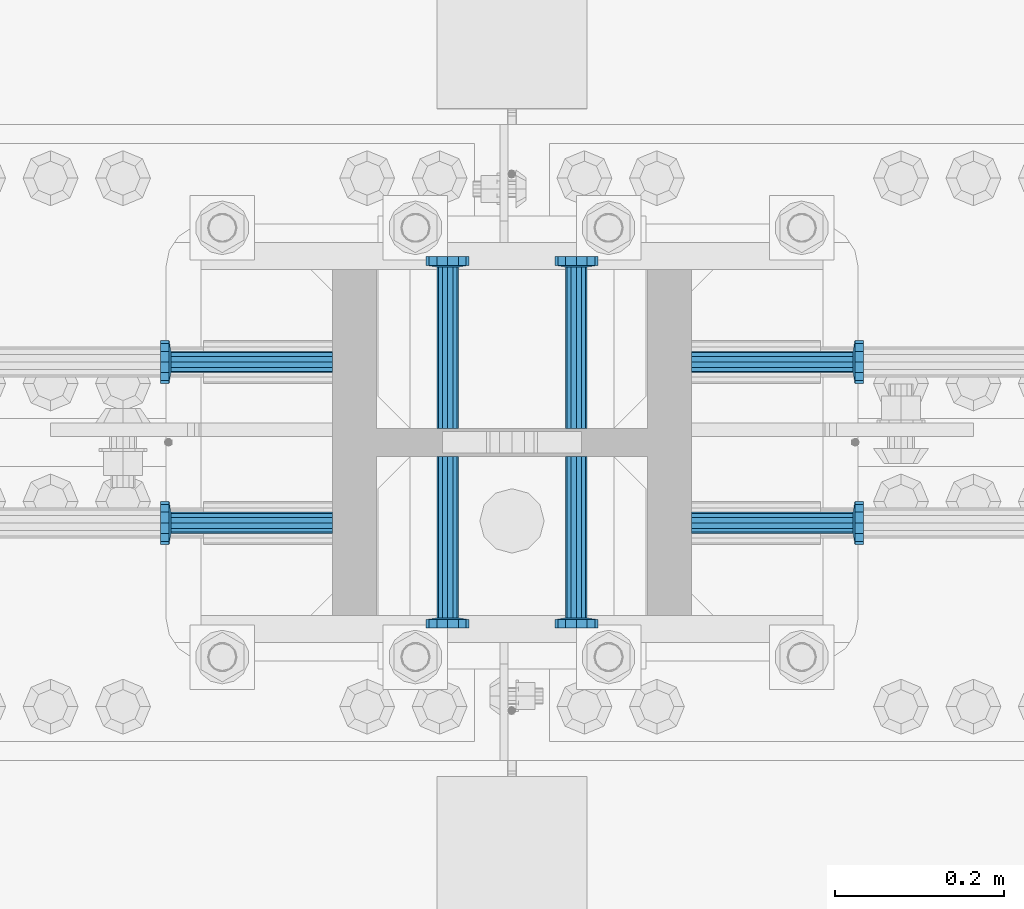
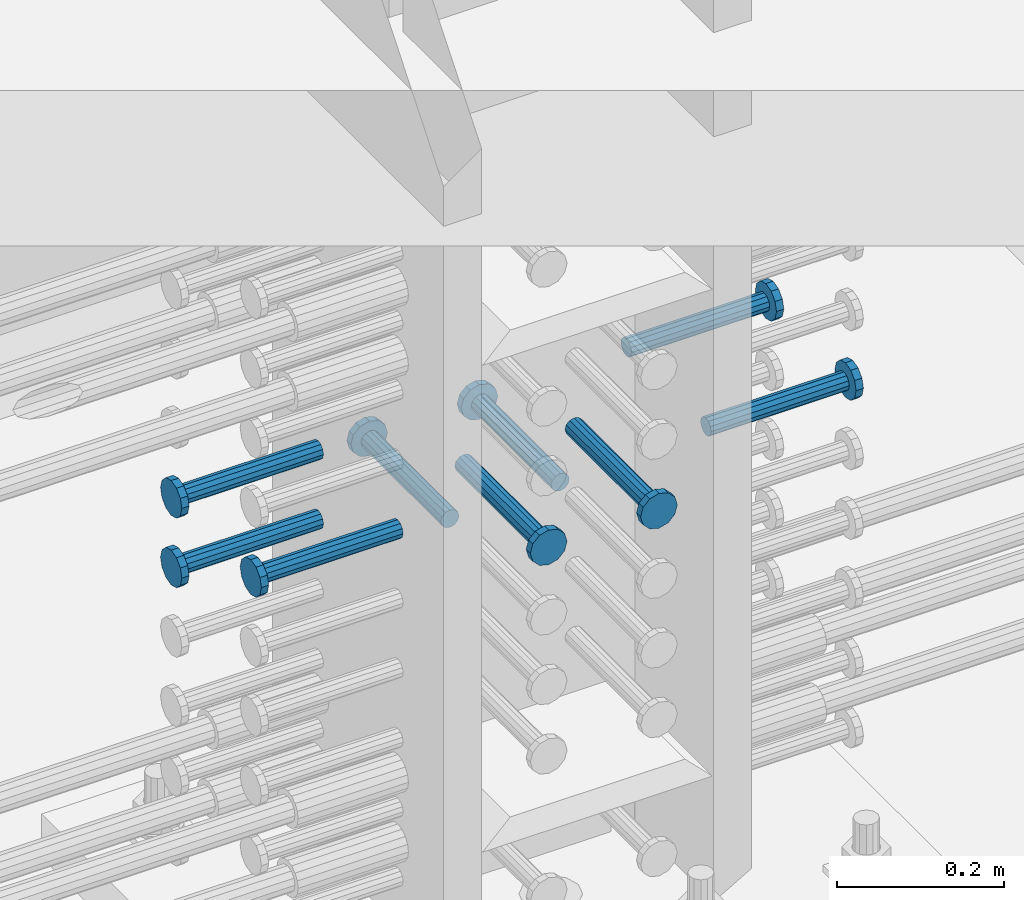
# One storey, part 1219 of 1763: 9 beams, 1 element without a shape of its own.
"""IFC2X3 building model written with IfcOpenShell, lengths in millimetres."""

from ifc_helpers import new_model, si_unit, frame, origin_with_axes, place, context, subcontext, project, spatial, faceted_brep, material, type_object, element, aggregate, save


model = new_model("IFC2X3")

# Units and contexts
model_context = context("Model", 3, precision=1e-05, world=origin_with_axes())
body_context = subcontext(model_context, "Body", "Model", "MODEL_VIEW")
ifc_project = project(units=[si_unit("LENGTHUNIT", "METRE", prefix="MILLI"), si_unit("AREAUNIT", "SQUARE_METRE"), si_unit("VOLUMEUNIT", "CUBIC_METRE"), si_unit("MASSUNIT", "GRAM", prefix="KILO"), si_unit("TIMEUNIT", "SECOND"), si_unit("PLANEANGLEUNIT", "RADIAN"), si_unit("SOLIDANGLEUNIT", "STERADIAN"), si_unit("THERMODYNAMICTEMPERATUREUNIT", "DEGREE_CELSIUS"), si_unit("LUMINOUSINTENSITYUNIT", "LUMEN")], contexts=[model_context])

# Site, building, storey
site_placement = place(None, origin_with_axes())
site = spatial("IfcSite", under=ifc_project, at=site_placement, CompositionType="ELEMENT")
building_placement = place(site_placement, origin_with_axes())
building = spatial("IfcBuilding", under=site, at=building_placement, Name="Undefined", CompositionType="ELEMENT")
storey_placement = place(building_placement, origin_with_axes())
storey = spatial("IfcBuildingStorey", under=building, at=storey_placement, Name="Undefined", CompositionType="ELEMENT", Elevation=0.0)

# Assembly, beams
assembly_placement = place(storey_placement, origin_with_axes())
assembly = element("IfcElementAssembly", 1, at=assembly_placement, inside=storey, Name="COLUMN", AssemblyPlace="NOTDEFINED", PredefinedType="RIGID_FRAME")
ifc_material = material(Name="STEEL/A108")
beam_type = type_object("IfcBeamType", PredefinedType="NOTDEFINED")
beam_1_placement = place(assembly_placement, frame((-61807.1622049631, 552.449999999823, 4521.20000000005), z_axis=(0.0, 1.0, 0.0), x_axis=(-1.0, 0.0, 0.0)))
beam_1 = element("IfcBeam", 2, at=beam_1_placement, type_object=beam_type, material=ifc_material, Name="HEADED STUD ANCHOR", context=body_context, shape_type="Brep", body=[
    faceted_brep([(0.0, -12.6999999999971, -1.81898940354586e-12), (3.63797880709171e-12, -11.0, -6.34999990463257), (191.00799999576, -11.0, -6.34999990454889), (191.007999995752, -12.6999998092651, 8.36735125631094e-11), (7.27595761418343e-12, -6.34999990463257, -11.0), (191.00799999576, -6.34999990463257, -10.9999999999163), (3.63797880709171e-12, 0.0, -12.6999998092651), (191.00799999576, 0.0, -12.6999998091815), (7.27595761418343e-12, 6.34999990463257, -11.0), (191.00799999576, 6.34999990463257, -10.9999999999163), (3.63797880709171e-12, 11.0, -6.34999990463257), (191.00799999576, 11.0, -6.34999990454889), (0.0, 12.6999999999971, -1.81898940354586e-12), (191.007999995752, 12.6999998092651, 8.36735125631094e-11), (0.0, 11.0, 6.34999990463257), (191.007999995752, 11.0, 6.34999990471624), (-3.63797880709171e-12, 6.34999990463257, 11.0), (191.007999995749, 6.34999990463257, 11.0000000000837), (-3.63797880709171e-12, 0.0, 12.6999998092651), (191.007999995749, 0.0, 12.6999998093488), (-3.63797880709171e-12, -6.34999990463257, 11.0), (191.007999995749, -6.34999990463257, 11.0000000000837), (0.0, -11.0, 6.34999990463257), (191.007999995752, -11.0, 6.34999990471624), (193.039999995715, -22.0, -12.6999998091796), (193.039999995708, -25.3999996185303, 8.54925019666553e-11), (193.039999995719, -12.6999998092651, -21.9999999999145), (193.039999995719, 0.0, -25.3999996184448), (193.039999995719, 12.6999998092651, -21.9999999999145), (193.039999995715, 22.0, -12.6999998091796), (193.039999995708, 25.3999996185303, 8.54925019666553e-11), (193.039999995704, 22.0, 12.6999998093506), (193.039999995701, 12.6999998092651, 22.0000000000855), (193.039999995697, 0.0, 25.3999996186158), (193.039999995701, -12.6999998092651, 22.0000000000855), (193.039999995704, -22.0, 12.6999998093506), (203.199999995486, -22.0, -12.6999998091742), (203.199999995482, -25.3999996185303, 9.09494701772928e-11), (203.199999995493, -12.6999998092651, -21.9999999999091), (203.199999995493, 0.0, -25.3999996184393), (203.199999995493, 12.6999998092651, -21.9999999999091), (203.199999995486, 22.0, -12.6999998091742), (203.199999995482, 25.3999996185303, 9.09494701772928e-11), (203.199999995479, 22.0, 12.6999998093561), (203.199999995475, 12.6999998092651, 22.0000000000909), (203.199999995471, 0.0, 25.3999996186212), (203.199999995475, -12.6999998092651, 22.0000000000909), (203.199999995479, -22.0, 12.6999998093561)], [[[0, 1, 2, 3]], [[1, 4, 5, 2]], [[4, 6, 7, 5]], [[6, 8, 9, 7]], [[8, 10, 11, 9]], [[10, 12, 13, 11]], [[12, 14, 15, 13]], [[14, 16, 17, 15]], [[16, 18, 19, 17]], [[18, 20, 21, 19]], [[20, 22, 23, 21]], [[22, 0, 3, 23]], [[22, 20, 18, 16, 14, 12, 10, 8, 6, 4, 1, 0]], [[3, 2, 24, 25]], [[2, 5, 26, 24]], [[5, 7, 27, 26]], [[7, 9, 28, 27]], [[9, 11, 29, 28]], [[11, 13, 30, 29]], [[13, 15, 31, 30]], [[15, 17, 32, 31]], [[17, 19, 33, 32]], [[19, 21, 34, 33]], [[21, 23, 35, 34]], [[23, 3, 25, 35]], [[25, 24, 36, 37]], [[24, 26, 38, 36]], [[26, 27, 39, 38]], [[27, 28, 40, 39]], [[28, 29, 41, 40]], [[29, 30, 42, 41]], [[30, 31, 43, 42]], [[31, 32, 44, 43]], [[32, 33, 45, 44]], [[33, 34, 46, 45]], [[34, 35, 47, 46]], [[35, 25, 37, 47]], [[38, 39, 40, 41, 42, 43, 44, 45, 46, 47, 37, 36]]]),
])
beam_2_placement = place(assembly_placement, frame((-61807.1622736986, 361.949999999998, 4521.20000000005), z_axis=(0.0, 1.0, 0.0), x_axis=(-1.0, 0.0, 0.0)))
beam_2 = element("IfcBeam", 3, at=beam_2_placement, type_object=beam_type, material=ifc_material, Name="HEADED STUD ANCHOR", context=body_context, shape_type="Brep", body=[
    faceted_brep([(0.0, -12.6999999999971, -1.81898940354586e-12), (3.63797880709171e-12, -11.0, -6.34999990463257), (191.00799999576, -11.0, -6.34999990454889), (191.007999995752, -12.6999998092651, 8.36735125631094e-11), (7.27595761418343e-12, -6.34999990463257, -11.0), (191.00799999576, -6.34999990463257, -10.9999999999163), (3.63797880709171e-12, 0.0, -12.6999998092651), (191.00799999576, 0.0, -12.6999998091815), (7.27595761418343e-12, 6.34999990463257, -11.0), (191.00799999576, 6.34999990463257, -10.9999999999163), (3.63797880709171e-12, 11.0, -6.34999990463257), (191.00799999576, 11.0, -6.34999990454889), (0.0, 12.6999999999971, -1.81898940354586e-12), (191.007999995752, 12.6999998092651, 8.36735125631094e-11), (0.0, 11.0, 6.34999990463257), (191.007999995752, 11.0, 6.34999990471624), (-3.63797880709171e-12, 6.34999990463257, 11.0), (191.007999995749, 6.34999990463257, 11.0000000000837), (-3.63797880709171e-12, 0.0, 12.6999998092651), (191.007999995749, 0.0, 12.6999998093488), (-3.63797880709171e-12, -6.34999990463257, 11.0), (191.007999995749, -6.34999990463257, 11.0000000000837), (0.0, -11.0, 6.34999990463257), (191.007999995752, -11.0, 6.34999990471624), (193.039999995715, -22.0, -12.6999998091796), (193.039999995708, -25.3999996185303, 8.54925019666553e-11), (193.039999995719, -12.6999998092651, -21.9999999999145), (193.039999995719, 0.0, -25.3999996184448), (193.039999995719, 12.6999998092651, -21.9999999999145), (193.039999995715, 22.0, -12.6999998091796), (193.039999995708, 25.3999996185303, 8.54925019666553e-11), (193.039999995704, 22.0, 12.6999998093506), (193.039999995701, 12.6999998092651, 22.0000000000855), (193.039999995697, 0.0, 25.3999996186158), (193.039999995701, -12.6999998092651, 22.0000000000855), (193.039999995704, -22.0, 12.6999998093506), (203.199999995486, -22.0, -12.6999998091742), (203.199999995482, -25.3999996185303, 9.09494701772928e-11), (203.199999995493, -12.6999998092651, -21.9999999999091), (203.199999995493, 0.0, -25.3999996184393), (203.199999995493, 12.6999998092651, -21.9999999999091), (203.199999995486, 22.0, -12.6999998091742), (203.199999995482, 25.3999996185303, 9.09494701772928e-11), (203.199999995479, 22.0, 12.6999998093561), (203.199999995475, 12.6999998092651, 22.0000000000909), (203.199999995471, 0.0, 25.3999996186212), (203.199999995475, -12.6999998092651, 22.0000000000909), (203.199999995479, -22.0, 12.6999998093561)], [[[0, 1, 2, 3]], [[1, 4, 5, 2]], [[4, 6, 7, 5]], [[6, 8, 9, 7]], [[8, 10, 11, 9]], [[10, 12, 13, 11]], [[12, 14, 15, 13]], [[14, 16, 17, 15]], [[16, 18, 19, 17]], [[18, 20, 21, 19]], [[20, 22, 23, 21]], [[22, 0, 3, 23]], [[22, 20, 18, 16, 14, 12, 10, 8, 6, 4, 1, 0]], [[3, 2, 24, 25]], [[2, 5, 26, 24]], [[5, 7, 27, 26]], [[7, 9, 28, 27]], [[9, 11, 29, 28]], [[11, 13, 30, 29]], [[13, 15, 31, 30]], [[15, 17, 32, 31]], [[17, 19, 33, 32]], [[19, 21, 34, 33]], [[21, 23, 35, 34]], [[23, 3, 25, 35]], [[25, 24, 36, 37]], [[24, 26, 38, 36]], [[26, 27, 39, 38]], [[27, 28, 40, 39]], [[28, 29, 41, 40]], [[29, 30, 42, 41]], [[30, 31, 43, 42]], [[31, 32, 44, 43]], [[32, 33, 45, 44]], [[33, 34, 46, 45]], [[34, 35, 47, 46]], [[35, 25, 37, 47]], [[38, 39, 40, 41, 42, 43, 44, 45, 46, 47, 37, 36]]]),
])
beam_3_placement = place(assembly_placement, frame((-61670.6373420916, 440.53099988573, 4521.20000000005), z_axis=(1.0, 0.0, 0.0), x_axis=(0.0, -1.0, 0.0)))
beam_3 = element("IfcBeam", 4, at=beam_3_placement, type_object=beam_type, material=ifc_material, Name="HEADED STUD ANCHOR", context=body_context, shape_type="Brep", body=[
    faceted_brep([(0.0, -12.6999999999971, -1.81898940354586e-12), (3.63797880709171e-12, -11.0, -6.34999990463257), (191.00799999576, -11.0, -6.34999990454889), (191.007999995752, -12.6999998092651, 8.36735125631094e-11), (7.27595761418343e-12, -6.34999990463257, -11.0), (191.00799999576, -6.34999990463257, -10.9999999999163), (3.63797880709171e-12, 0.0, -12.6999998092651), (191.00799999576, 0.0, -12.6999998091815), (7.27595761418343e-12, 6.34999990463257, -11.0), (191.00799999576, 6.34999990463257, -10.9999999999163), (3.63797880709171e-12, 11.0, -6.34999990463257), (191.00799999576, 11.0, -6.34999990454889), (0.0, 12.6999999999971, -1.81898940354586e-12), (191.007999995752, 12.6999998092651, 8.36735125631094e-11), (0.0, 11.0, 6.34999990463257), (191.007999995752, 11.0, 6.34999990471624), (-3.63797880709171e-12, 6.34999990463257, 11.0), (191.007999995749, 6.34999990463257, 11.0000000000837), (-3.63797880709171e-12, 0.0, 12.6999998092651), (191.007999995749, 0.0, 12.6999998093488), (-3.63797880709171e-12, -6.34999990463257, 11.0), (191.007999995749, -6.34999990463257, 11.0000000000837), (0.0, -11.0, 6.34999990463257), (191.007999995752, -11.0, 6.34999990471624), (193.039999995715, -22.0, -12.6999998091796), (193.039999995708, -25.3999996185303, 8.54925019666553e-11), (193.039999995719, -12.6999998092651, -21.9999999999145), (193.039999995719, 0.0, -25.3999996184448), (193.039999995719, 12.6999998092651, -21.9999999999145), (193.039999995715, 22.0, -12.6999998091796), (193.039999995708, 25.3999996185303, 8.54925019666553e-11), (193.039999995704, 22.0, 12.6999998093506), (193.039999995701, 12.6999998092651, 22.0000000000855), (193.039999995697, 0.0, 25.3999996186158), (193.039999995701, -12.6999998092651, 22.0000000000855), (193.039999995704, -22.0, 12.6999998093506), (203.199999995486, -22.0, -12.6999998091742), (203.199999995482, -25.3999996185303, 9.09494701772928e-11), (203.199999995493, -12.6999998092651, -21.9999999999091), (203.199999995493, 0.0, -25.3999996184393), (203.199999995493, 12.6999998092651, -21.9999999999091), (203.199999995486, 22.0, -12.6999998091742), (203.199999995482, 25.3999996185303, 9.09494701772928e-11), (203.199999995479, 22.0, 12.6999998093561), (203.199999995475, 12.6999998092651, 22.0000000000909), (203.199999995471, 0.0, 25.3999996186212), (203.199999995475, -12.6999998092651, 22.0000000000909), (203.199999995479, -22.0, 12.6999998093561)], [[[0, 1, 2, 3]], [[1, 4, 5, 2]], [[4, 6, 7, 5]], [[6, 8, 9, 7]], [[8, 10, 11, 9]], [[10, 12, 13, 11]], [[12, 14, 15, 13]], [[14, 16, 17, 15]], [[16, 18, 19, 17]], [[18, 20, 21, 19]], [[20, 22, 23, 21]], [[22, 0, 3, 23]], [[22, 20, 18, 16, 14, 12, 10, 8, 6, 4, 1, 0]], [[3, 2, 24, 25]], [[2, 5, 26, 24]], [[5, 7, 27, 26]], [[7, 9, 28, 27]], [[9, 11, 29, 28]], [[11, 13, 30, 29]], [[13, 15, 31, 30]], [[15, 17, 32, 31]], [[17, 19, 33, 32]], [[19, 21, 34, 33]], [[21, 23, 35, 34]], [[23, 3, 25, 35]], [[25, 24, 36, 37]], [[24, 26, 38, 36]], [[26, 27, 39, 38]], [[27, 28, 40, 39]], [[28, 29, 41, 40]], [[29, 30, 42, 41]], [[30, 31, 43, 42]], [[31, 32, 44, 43]], [[32, 33, 45, 44]], [[33, 34, 46, 45]], [[34, 35, 47, 46]], [[35, 25, 37, 47]], [[38, 39, 40, 41, 42, 43, 44, 45, 46, 47, 37, 36]]]),
])
beam_4_placement = place(assembly_placement, frame((-61518.2373420926, 440.531000000006, 4521.20000000005), z_axis=(1.0, 0.0, 0.0), x_axis=(0.0, -1.0, 0.0)))
beam_4 = element("IfcBeam", 5, at=beam_4_placement, type_object=beam_type, material=ifc_material, Name="HEADED STUD ANCHOR", context=body_context, shape_type="Brep", body=[
    faceted_brep([(0.0, -12.6999999999971, -1.81898940354586e-12), (3.63797880709171e-12, -11.0, -6.34999990463257), (191.00799999576, -11.0, -6.34999990454889), (191.007999995752, -12.6999998092651, 8.36735125631094e-11), (7.27595761418343e-12, -6.34999990463257, -11.0), (191.00799999576, -6.34999990463257, -10.9999999999163), (3.63797880709171e-12, 0.0, -12.6999998092651), (191.00799999576, 0.0, -12.6999998091815), (7.27595761418343e-12, 6.34999990463257, -11.0), (191.00799999576, 6.34999990463257, -10.9999999999163), (3.63797880709171e-12, 11.0, -6.34999990463257), (191.00799999576, 11.0, -6.34999990454889), (0.0, 12.6999999999971, -1.81898940354586e-12), (191.007999995752, 12.6999998092651, 8.36735125631094e-11), (0.0, 11.0, 6.34999990463257), (191.007999995752, 11.0, 6.34999990471624), (-3.63797880709171e-12, 6.34999990463257, 11.0), (191.007999995749, 6.34999990463257, 11.0000000000837), (-3.63797880709171e-12, 0.0, 12.6999998092651), (191.007999995749, 0.0, 12.6999998093488), (-3.63797880709171e-12, -6.34999990463257, 11.0), (191.007999995749, -6.34999990463257, 11.0000000000837), (0.0, -11.0, 6.34999990463257), (191.007999995752, -11.0, 6.34999990471624), (193.039999995715, -22.0, -12.6999998091796), (193.039999995708, -25.3999996185303, 8.54925019666553e-11), (193.039999995719, -12.6999998092651, -21.9999999999145), (193.039999995719, 0.0, -25.3999996184448), (193.039999995719, 12.6999998092651, -21.9999999999145), (193.039999995715, 22.0, -12.6999998091796), (193.039999995708, 25.3999996185303, 8.54925019666553e-11), (193.039999995704, 22.0, 12.6999998093506), (193.039999995701, 12.6999998092651, 22.0000000000855), (193.039999995697, 0.0, 25.3999996186158), (193.039999995701, -12.6999998092651, 22.0000000000855), (193.039999995704, -22.0, 12.6999998093506), (203.199999995486, -22.0, -12.6999998091742), (203.199999995482, -25.3999996185303, 9.09494701772928e-11), (203.199999995493, -12.6999998092651, -21.9999999999091), (203.199999995493, 0.0, -25.3999996184393), (203.199999995493, 12.6999998092651, -21.9999999999091), (203.199999995486, 22.0, -12.6999998091742), (203.199999995482, 25.3999996185303, 9.09494701772928e-11), (203.199999995479, 22.0, 12.6999998093561), (203.199999995475, 12.6999998092651, 22.0000000000909), (203.199999995471, 0.0, 25.3999996186212), (203.199999995475, -12.6999998092651, 22.0000000000909), (203.199999995479, -22.0, 12.6999998093561)], [[[0, 1, 2, 3]], [[1, 4, 5, 2]], [[4, 6, 7, 5]], [[6, 8, 9, 7]], [[8, 10, 11, 9]], [[10, 12, 13, 11]], [[12, 14, 15, 13]], [[14, 16, 17, 15]], [[16, 18, 19, 17]], [[18, 20, 21, 19]], [[20, 22, 23, 21]], [[22, 0, 3, 23]], [[22, 20, 18, 16, 14, 12, 10, 8, 6, 4, 1, 0]], [[3, 2, 24, 25]], [[2, 5, 26, 24]], [[5, 7, 27, 26]], [[7, 9, 28, 27]], [[9, 11, 29, 28]], [[11, 13, 30, 29]], [[13, 15, 31, 30]], [[15, 17, 32, 31]], [[17, 19, 33, 32]], [[19, 21, 34, 33]], [[21, 23, 35, 34]], [[23, 3, 25, 35]], [[25, 24, 36, 37]], [[24, 26, 38, 36]], [[26, 27, 39, 38]], [[27, 28, 40, 39]], [[28, 29, 41, 40]], [[29, 30, 42, 41]], [[30, 31, 43, 42]], [[31, 32, 44, 43]], [[32, 33, 45, 44]], [[33, 34, 46, 45]], [[34, 35, 47, 46]], [[35, 25, 37, 47]], [[38, 39, 40, 41, 42, 43, 44, 45, 46, 47, 37, 36]]]),
])
beam_5_placement = place(assembly_placement, frame((-61381.7123210203, 361.950000000609, 4521.20000000005), z_axis=(0.0, 1.0, 0.0), x_axis=(1.0, 0.0, 0.0)))
beam_5 = element("IfcBeam", 6, at=beam_5_placement, type_object=beam_type, material=ifc_material, Name="HEADED STUD ANCHOR", context=body_context, shape_type="Brep", body=[
    faceted_brep([(0.0, -12.6999999999971, -1.81898940354586e-12), (3.63797880709171e-12, -11.0, -6.34999990463257), (191.00799999576, -11.0, -6.34999990454889), (191.007999995752, -12.6999998092651, 8.36735125631094e-11), (7.27595761418343e-12, -6.34999990463257, -11.0), (191.00799999576, -6.34999990463257, -10.9999999999163), (3.63797880709171e-12, 0.0, -12.6999998092651), (191.00799999576, 0.0, -12.6999998091815), (7.27595761418343e-12, 6.34999990463257, -11.0), (191.00799999576, 6.34999990463257, -10.9999999999163), (3.63797880709171e-12, 11.0, -6.34999990463257), (191.00799999576, 11.0, -6.34999990454889), (0.0, 12.6999999999971, -1.81898940354586e-12), (191.007999995752, 12.6999998092651, 8.36735125631094e-11), (0.0, 11.0, 6.34999990463257), (191.007999995752, 11.0, 6.34999990471624), (-3.63797880709171e-12, 6.34999990463257, 11.0), (191.007999995749, 6.34999990463257, 11.0000000000837), (-3.63797880709171e-12, 0.0, 12.6999998092651), (191.007999995749, 0.0, 12.6999998093488), (-3.63797880709171e-12, -6.34999990463257, 11.0), (191.007999995749, -6.34999990463257, 11.0000000000837), (0.0, -11.0, 6.34999990463257), (191.007999995752, -11.0, 6.34999990471624), (193.039999995715, -22.0, -12.6999998091796), (193.039999995708, -25.3999996185303, 8.54925019666553e-11), (193.039999995719, -12.6999998092651, -21.9999999999145), (193.039999995719, 0.0, -25.3999996184448), (193.039999995719, 12.6999998092651, -21.9999999999145), (193.039999995715, 22.0, -12.6999998091796), (193.039999995708, 25.3999996185303, 8.54925019666553e-11), (193.039999995704, 22.0, 12.6999998093506), (193.039999995701, 12.6999998092651, 22.0000000000855), (193.039999995697, 0.0, 25.3999996186158), (193.039999995701, -12.6999998092651, 22.0000000000855), (193.039999995704, -22.0, 12.6999998093506), (203.199999995486, -22.0, -12.6999998091742), (203.199999995482, -25.3999996185303, 9.09494701772928e-11), (203.199999995493, -12.6999998092651, -21.9999999999091), (203.199999995493, 0.0, -25.3999996184393), (203.199999995493, 12.6999998092651, -21.9999999999091), (203.199999995486, 22.0, -12.6999998091742), (203.199999995482, 25.3999996185303, 9.09494701772928e-11), (203.199999995479, 22.0, 12.6999998093561), (203.199999995475, 12.6999998092651, 22.0000000000909), (203.199999995471, 0.0, 25.3999996186212), (203.199999995475, -12.6999998092651, 22.0000000000909), (203.199999995479, -22.0, 12.6999998093561)], [[[0, 1, 2, 3]], [[1, 4, 5, 2]], [[4, 6, 7, 5]], [[6, 8, 9, 7]], [[8, 10, 11, 9]], [[10, 12, 13, 11]], [[12, 14, 15, 13]], [[14, 16, 17, 15]], [[16, 18, 19, 17]], [[18, 20, 21, 19]], [[20, 22, 23, 21]], [[22, 0, 3, 23]], [[22, 20, 18, 16, 14, 12, 10, 8, 6, 4, 1, 0]], [[3, 2, 24, 25]], [[2, 5, 26, 24]], [[5, 7, 27, 26]], [[7, 9, 28, 27]], [[9, 11, 29, 28]], [[11, 13, 30, 29]], [[13, 15, 31, 30]], [[15, 17, 32, 31]], [[17, 19, 33, 32]], [[19, 21, 34, 33]], [[21, 23, 35, 34]], [[23, 3, 25, 35]], [[25, 24, 36, 37]], [[24, 26, 38, 36]], [[26, 27, 39, 38]], [[27, 28, 40, 39]], [[28, 29, 41, 40]], [[29, 30, 42, 41]], [[30, 31, 43, 42]], [[31, 32, 44, 43]], [[32, 33, 45, 44]], [[33, 34, 46, 45]], [[34, 35, 47, 46]], [[35, 25, 37, 47]], [[38, 39, 40, 41, 42, 43, 44, 45, 46, 47, 37, 36]]]),
])
beam_6_placement = place(assembly_placement, frame((-61381.7122523598, 552.449999999998, 4521.20000000005), z_axis=(0.0, 1.0, 0.0), x_axis=(1.0, 0.0, 0.0)))
beam_6 = element("IfcBeam", 7, at=beam_6_placement, type_object=beam_type, material=ifc_material, Name="HEADED STUD ANCHOR", context=body_context, shape_type="Brep", body=[
    faceted_brep([(0.0, -12.6999999999971, -1.81898940354586e-12), (3.63797880709171e-12, -11.0, -6.34999990463257), (191.00799999576, -11.0, -6.34999990454889), (191.007999995752, -12.6999998092651, 8.36735125631094e-11), (7.27595761418343e-12, -6.34999990463257, -11.0), (191.00799999576, -6.34999990463257, -10.9999999999163), (3.63797880709171e-12, 0.0, -12.6999998092651), (191.00799999576, 0.0, -12.6999998091815), (7.27595761418343e-12, 6.34999990463257, -11.0), (191.00799999576, 6.34999990463257, -10.9999999999163), (3.63797880709171e-12, 11.0, -6.34999990463257), (191.00799999576, 11.0, -6.34999990454889), (0.0, 12.6999999999971, -1.81898940354586e-12), (191.007999995752, 12.6999998092651, 8.36735125631094e-11), (0.0, 11.0, 6.34999990463257), (191.007999995752, 11.0, 6.34999990471624), (-3.63797880709171e-12, 6.34999990463257, 11.0), (191.007999995749, 6.34999990463257, 11.0000000000837), (-3.63797880709171e-12, 0.0, 12.6999998092651), (191.007999995749, 0.0, 12.6999998093488), (-3.63797880709171e-12, -6.34999990463257, 11.0), (191.007999995749, -6.34999990463257, 11.0000000000837), (0.0, -11.0, 6.34999990463257), (191.007999995752, -11.0, 6.34999990471624), (193.039999995715, -22.0, -12.6999998091796), (193.039999995708, -25.3999996185303, 8.54925019666553e-11), (193.039999995719, -12.6999998092651, -21.9999999999145), (193.039999995719, 0.0, -25.3999996184448), (193.039999995719, 12.6999998092651, -21.9999999999145), (193.039999995715, 22.0, -12.6999998091796), (193.039999995708, 25.3999996185303, 8.54925019666553e-11), (193.039999995704, 22.0, 12.6999998093506), (193.039999995701, 12.6999998092651, 22.0000000000855), (193.039999995697, 0.0, 25.3999996186158), (193.039999995701, -12.6999998092651, 22.0000000000855), (193.039999995704, -22.0, 12.6999998093506), (203.199999995486, -22.0, -12.6999998091742), (203.199999995482, -25.3999996185303, 9.09494701772928e-11), (203.199999995493, -12.6999998092651, -21.9999999999091), (203.199999995493, 0.0, -25.3999996184393), (203.199999995493, 12.6999998092651, -21.9999999999091), (203.199999995486, 22.0, -12.6999998091742), (203.199999995482, 25.3999996185303, 9.09494701772928e-11), (203.199999995479, 22.0, 12.6999998093561), (203.199999995475, 12.6999998092651, 22.0000000000909), (203.199999995471, 0.0, 25.3999996186212), (203.199999995475, -12.6999998092651, 22.0000000000909), (203.199999995479, -22.0, 12.6999998093561)], [[[0, 1, 2, 3]], [[1, 4, 5, 2]], [[4, 6, 7, 5]], [[6, 8, 9, 7]], [[8, 10, 11, 9]], [[10, 12, 13, 11]], [[12, 14, 15, 13]], [[14, 16, 17, 15]], [[16, 18, 19, 17]], [[18, 20, 21, 19]], [[20, 22, 23, 21]], [[22, 0, 3, 23]], [[22, 20, 18, 16, 14, 12, 10, 8, 6, 4, 1, 0]], [[3, 2, 24, 25]], [[2, 5, 26, 24]], [[5, 7, 27, 26]], [[7, 9, 28, 27]], [[9, 11, 29, 28]], [[11, 13, 30, 29]], [[13, 15, 31, 30]], [[15, 17, 32, 31]], [[17, 19, 33, 32]], [[19, 21, 34, 33]], [[21, 23, 35, 34]], [[23, 3, 25, 35]], [[25, 24, 36, 37]], [[24, 26, 38, 36]], [[26, 27, 39, 38]], [[27, 28, 40, 39]], [[28, 29, 41, 40]], [[29, 30, 42, 41]], [[30, 31, 43, 42]], [[31, 32, 44, 43]], [[32, 33, 45, 44]], [[33, 34, 46, 45]], [[34, 35, 47, 46]], [[35, 25, 37, 47]], [[38, 39, 40, 41, 42, 43, 44, 45, 46, 47, 37, 36]]]),
])
beam_7_placement = place(assembly_placement, frame((-61518.2373431004, 473.869000000006, 4419.60000000004), z_axis=(1.0, 0.0, 0.0), x_axis=(0.0, 1.0, 0.0)))
beam_7 = element("IfcBeam", 8, at=beam_7_placement, type_object=beam_type, material=ifc_material, Name="HEADED STUD ANCHOR", context=body_context, shape_type="Brep", body=[
    faceted_brep([(0.0, -12.6999999999971, -1.81898940354586e-12), (3.63797880709171e-12, -11.0, -6.34999990463257), (191.00799999576, -11.0, -6.34999990454889), (191.007999995752, -12.6999998092651, 8.36735125631094e-11), (7.27595761418343e-12, -6.34999990463257, -11.0), (191.00799999576, -6.34999990463257, -10.9999999999163), (3.63797880709171e-12, 0.0, -12.6999998092651), (191.00799999576, 0.0, -12.6999998091815), (7.27595761418343e-12, 6.34999990463257, -11.0), (191.00799999576, 6.34999990463257, -10.9999999999163), (3.63797880709171e-12, 11.0, -6.34999990463257), (191.00799999576, 11.0, -6.34999990454889), (0.0, 12.6999999999971, -1.81898940354586e-12), (191.007999995752, 12.6999998092651, 8.36735125631094e-11), (0.0, 11.0, 6.34999990463257), (191.007999995752, 11.0, 6.34999990471624), (-3.63797880709171e-12, 6.34999990463257, 11.0), (191.007999995749, 6.34999990463257, 11.0000000000837), (-3.63797880709171e-12, 0.0, 12.6999998092651), (191.007999995749, 0.0, 12.6999998093488), (-3.63797880709171e-12, -6.34999990463257, 11.0), (191.007999995749, -6.34999990463257, 11.0000000000837), (0.0, -11.0, 6.34999990463257), (191.007999995752, -11.0, 6.34999990471624), (193.039999995715, -22.0, -12.6999998091796), (193.039999995708, -25.3999996185303, 8.54925019666553e-11), (193.039999995719, -12.6999998092651, -21.9999999999145), (193.039999995719, 0.0, -25.3999996184448), (193.039999995719, 12.6999998092651, -21.9999999999145), (193.039999995715, 22.0, -12.6999998091796), (193.039999995708, 25.3999996185303, 8.54925019666553e-11), (193.039999995704, 22.0, 12.6999998093506), (193.039999995701, 12.6999998092651, 22.0000000000855), (193.039999995697, 0.0, 25.3999996186158), (193.039999995701, -12.6999998092651, 22.0000000000855), (193.039999995704, -22.0, 12.6999998093506), (203.199999995486, -22.0, -12.6999998091742), (203.199999995482, -25.3999996185303, 9.09494701772928e-11), (203.199999995493, -12.6999998092651, -21.9999999999091), (203.199999995493, 0.0, -25.3999996184393), (203.199999995493, 12.6999998092651, -21.9999999999091), (203.199999995486, 22.0, -12.6999998091742), (203.199999995482, 25.3999996185303, 9.09494701772928e-11), (203.199999995479, 22.0, 12.6999998093561), (203.199999995475, 12.6999998092651, 22.0000000000909), (203.199999995471, 0.0, 25.3999996186212), (203.199999995475, -12.6999998092651, 22.0000000000909), (203.199999995479, -22.0, 12.6999998093561)], [[[0, 1, 2, 3]], [[1, 4, 5, 2]], [[4, 6, 7, 5]], [[6, 8, 9, 7]], [[8, 10, 11, 9]], [[10, 12, 13, 11]], [[12, 14, 15, 13]], [[14, 16, 17, 15]], [[16, 18, 19, 17]], [[18, 20, 21, 19]], [[20, 22, 23, 21]], [[22, 0, 3, 23]], [[22, 20, 18, 16, 14, 12, 10, 8, 6, 4, 1, 0]], [[3, 2, 24, 25]], [[2, 5, 26, 24]], [[5, 7, 27, 26]], [[7, 9, 28, 27]], [[9, 11, 29, 28]], [[11, 13, 30, 29]], [[13, 15, 31, 30]], [[15, 17, 32, 31]], [[17, 19, 33, 32]], [[19, 21, 34, 33]], [[21, 23, 35, 34]], [[23, 3, 25, 35]], [[25, 24, 36, 37]], [[24, 26, 38, 36]], [[26, 27, 39, 38]], [[27, 28, 40, 39]], [[28, 29, 41, 40]], [[29, 30, 42, 41]], [[30, 31, 43, 42]], [[31, 32, 44, 43]], [[32, 33, 45, 44]], [[33, 34, 46, 45]], [[34, 35, 47, 46]], [[35, 25, 37, 47]], [[38, 39, 40, 41, 42, 43, 44, 45, 46, 47, 37, 36]]]),
])
beam_8_placement = place(assembly_placement, frame((-61670.6373431002, 473.868999002865, 4419.60000000004), z_axis=(1.0, 0.0, 0.0), x_axis=(0.0, 1.0, 0.0)))
beam_8 = element("IfcBeam", 9, at=beam_8_placement, type_object=beam_type, material=ifc_material, Name="HEADED STUD ANCHOR", context=body_context, shape_type="Brep", body=[
    faceted_brep([(0.0, -12.6999999999971, -1.81898940354586e-12), (3.63797880709171e-12, -11.0, -6.34999990463257), (191.00799999576, -11.0, -6.34999990454889), (191.007999995752, -12.6999998092651, 8.36735125631094e-11), (7.27595761418343e-12, -6.34999990463257, -11.0), (191.00799999576, -6.34999990463257, -10.9999999999163), (3.63797880709171e-12, 0.0, -12.6999998092651), (191.00799999576, 0.0, -12.6999998091815), (7.27595761418343e-12, 6.34999990463257, -11.0), (191.00799999576, 6.34999990463257, -10.9999999999163), (3.63797880709171e-12, 11.0, -6.34999990463257), (191.00799999576, 11.0, -6.34999990454889), (0.0, 12.6999999999971, -1.81898940354586e-12), (191.007999995752, 12.6999998092651, 8.36735125631094e-11), (0.0, 11.0, 6.34999990463257), (191.007999995752, 11.0, 6.34999990471624), (-3.63797880709171e-12, 6.34999990463257, 11.0), (191.007999995749, 6.34999990463257, 11.0000000000837), (-3.63797880709171e-12, 0.0, 12.6999998092651), (191.007999995749, 0.0, 12.6999998093488), (-3.63797880709171e-12, -6.34999990463257, 11.0), (191.007999995749, -6.34999990463257, 11.0000000000837), (0.0, -11.0, 6.34999990463257), (191.007999995752, -11.0, 6.34999990471624), (193.039999995715, -22.0, -12.6999998091796), (193.039999995708, -25.3999996185303, 8.54925019666553e-11), (193.039999995719, -12.6999998092651, -21.9999999999145), (193.039999995719, 0.0, -25.3999996184448), (193.039999995719, 12.6999998092651, -21.9999999999145), (193.039999995715, 22.0, -12.6999998091796), (193.039999995708, 25.3999996185303, 8.54925019666553e-11), (193.039999995704, 22.0, 12.6999998093506), (193.039999995701, 12.6999998092651, 22.0000000000855), (193.039999995697, 0.0, 25.3999996186158), (193.039999995701, -12.6999998092651, 22.0000000000855), (193.039999995704, -22.0, 12.6999998093506), (203.199999995486, -22.0, -12.6999998091742), (203.199999995482, -25.3999996185303, 9.09494701772928e-11), (203.199999995493, -12.6999998092651, -21.9999999999091), (203.199999995493, 0.0, -25.3999996184393), (203.199999995493, 12.6999998092651, -21.9999999999091), (203.199999995486, 22.0, -12.6999998091742), (203.199999995482, 25.3999996185303, 9.09494701772928e-11), (203.199999995479, 22.0, 12.6999998093561), (203.199999995475, 12.6999998092651, 22.0000000000909), (203.199999995471, 0.0, 25.3999996186212), (203.199999995475, -12.6999998092651, 22.0000000000909), (203.199999995479, -22.0, 12.6999998093561)], [[[0, 1, 2, 3]], [[1, 4, 5, 2]], [[4, 6, 7, 5]], [[6, 8, 9, 7]], [[8, 10, 11, 9]], [[10, 12, 13, 11]], [[12, 14, 15, 13]], [[14, 16, 17, 15]], [[16, 18, 19, 17]], [[18, 20, 21, 19]], [[20, 22, 23, 21]], [[22, 0, 3, 23]], [[22, 20, 18, 16, 14, 12, 10, 8, 6, 4, 1, 0]], [[3, 2, 24, 25]], [[2, 5, 26, 24]], [[5, 7, 27, 26]], [[7, 9, 28, 27]], [[9, 11, 29, 28]], [[11, 13, 30, 29]], [[13, 15, 31, 30]], [[15, 17, 32, 31]], [[17, 19, 33, 32]], [[19, 21, 34, 33]], [[21, 23, 35, 34]], [[23, 3, 25, 35]], [[25, 24, 36, 37]], [[24, 26, 38, 36]], [[26, 27, 39, 38]], [[27, 28, 40, 39]], [[28, 29, 41, 40]], [[29, 30, 42, 41]], [[30, 31, 43, 42]], [[31, 32, 44, 43]], [[32, 33, 45, 44]], [[33, 34, 46, 45]], [[34, 35, 47, 46]], [[35, 25, 37, 47]], [[38, 39, 40, 41, 42, 43, 44, 45, 46, 47, 37, 36]]]),
])
beam_9_placement = place(assembly_placement, frame((-61807.1622049631, 552.449999999823, 4419.60000000004), z_axis=(0.0, 1.0, 0.0), x_axis=(-1.0, 0.0, 0.0)))
beam_9 = element("IfcBeam", 10, at=beam_9_placement, type_object=beam_type, material=ifc_material, Name="HEADED STUD ANCHOR", context=body_context, shape_type="Brep", body=[
    faceted_brep([(0.0, -12.6999999999971, -1.81898940354586e-12), (3.63797880709171e-12, -11.0, -6.34999990463257), (191.00799999576, -11.0, -6.34999990454889), (191.007999995752, -12.6999998092651, 8.36735125631094e-11), (7.27595761418343e-12, -6.34999990463257, -11.0), (191.00799999576, -6.34999990463257, -10.9999999999163), (3.63797880709171e-12, 0.0, -12.6999998092651), (191.00799999576, 0.0, -12.6999998091815), (7.27595761418343e-12, 6.34999990463257, -11.0), (191.00799999576, 6.34999990463257, -10.9999999999163), (3.63797880709171e-12, 11.0, -6.34999990463257), (191.00799999576, 11.0, -6.34999990454889), (0.0, 12.6999999999971, -1.81898940354586e-12), (191.007999995752, 12.6999998092651, 8.36735125631094e-11), (0.0, 11.0, 6.34999990463257), (191.007999995752, 11.0, 6.34999990471624), (-3.63797880709171e-12, 6.34999990463257, 11.0), (191.007999995749, 6.34999990463257, 11.0000000000837), (-3.63797880709171e-12, 0.0, 12.6999998092651), (191.007999995749, 0.0, 12.6999998093488), (-3.63797880709171e-12, -6.34999990463257, 11.0), (191.007999995749, -6.34999990463257, 11.0000000000837), (0.0, -11.0, 6.34999990463257), (191.007999995752, -11.0, 6.34999990471624), (193.039999995715, -22.0, -12.6999998091796), (193.039999995708, -25.3999996185303, 8.54925019666553e-11), (193.039999995719, -12.6999998092651, -21.9999999999145), (193.039999995719, 0.0, -25.3999996184448), (193.039999995719, 12.6999998092651, -21.9999999999145), (193.039999995715, 22.0, -12.6999998091796), (193.039999995708, 25.3999996185303, 8.54925019666553e-11), (193.039999995704, 22.0, 12.6999998093506), (193.039999995701, 12.6999998092651, 22.0000000000855), (193.039999995697, 0.0, 25.3999996186158), (193.039999995701, -12.6999998092651, 22.0000000000855), (193.039999995704, -22.0, 12.6999998093506), (203.199999995486, -22.0, -12.6999998091742), (203.199999995482, -25.3999996185303, 9.09494701772928e-11), (203.199999995493, -12.6999998092651, -21.9999999999091), (203.199999995493, 0.0, -25.3999996184393), (203.199999995493, 12.6999998092651, -21.9999999999091), (203.199999995486, 22.0, -12.6999998091742), (203.199999995482, 25.3999996185303, 9.09494701772928e-11), (203.199999995479, 22.0, 12.6999998093561), (203.199999995475, 12.6999998092651, 22.0000000000909), (203.199999995471, 0.0, 25.3999996186212), (203.199999995475, -12.6999998092651, 22.0000000000909), (203.199999995479, -22.0, 12.6999998093561)], [[[0, 1, 2, 3]], [[1, 4, 5, 2]], [[4, 6, 7, 5]], [[6, 8, 9, 7]], [[8, 10, 11, 9]], [[10, 12, 13, 11]], [[12, 14, 15, 13]], [[14, 16, 17, 15]], [[16, 18, 19, 17]], [[18, 20, 21, 19]], [[20, 22, 23, 21]], [[22, 0, 3, 23]], [[22, 20, 18, 16, 14, 12, 10, 8, 6, 4, 1, 0]], [[3, 2, 24, 25]], [[2, 5, 26, 24]], [[5, 7, 27, 26]], [[7, 9, 28, 27]], [[9, 11, 29, 28]], [[11, 13, 30, 29]], [[13, 15, 31, 30]], [[15, 17, 32, 31]], [[17, 19, 33, 32]], [[19, 21, 34, 33]], [[21, 23, 35, 34]], [[23, 3, 25, 35]], [[25, 24, 36, 37]], [[24, 26, 38, 36]], [[26, 27, 39, 38]], [[27, 28, 40, 39]], [[28, 29, 41, 40]], [[29, 30, 42, 41]], [[30, 31, 43, 42]], [[31, 32, 44, 43]], [[32, 33, 45, 44]], [[33, 34, 46, 45]], [[34, 35, 47, 46]], [[35, 25, 37, 47]], [[38, 39, 40, 41, 42, 43, 44, 45, 46, 47, 37, 36]]]),
])
aggregate(assembly, [beam_1, beam_2, beam_3, beam_4, beam_5, beam_6, beam_7, beam_8, beam_9])

save(model, "model.ifc")
